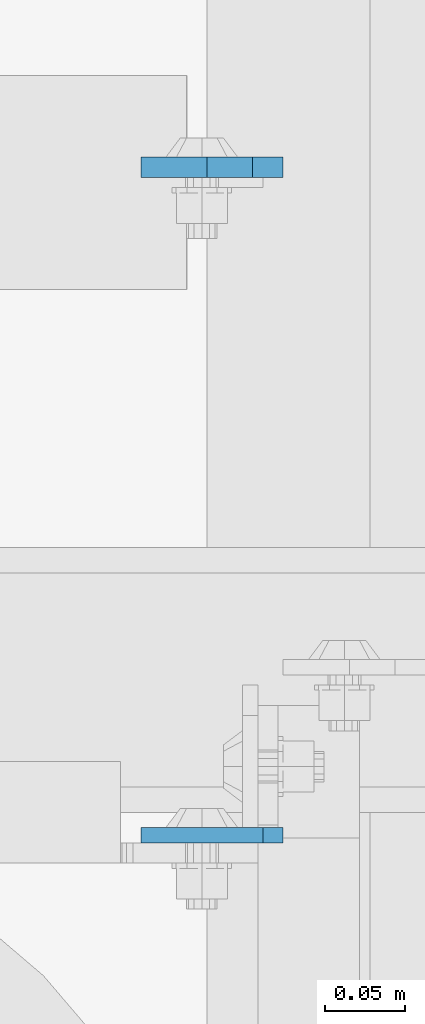
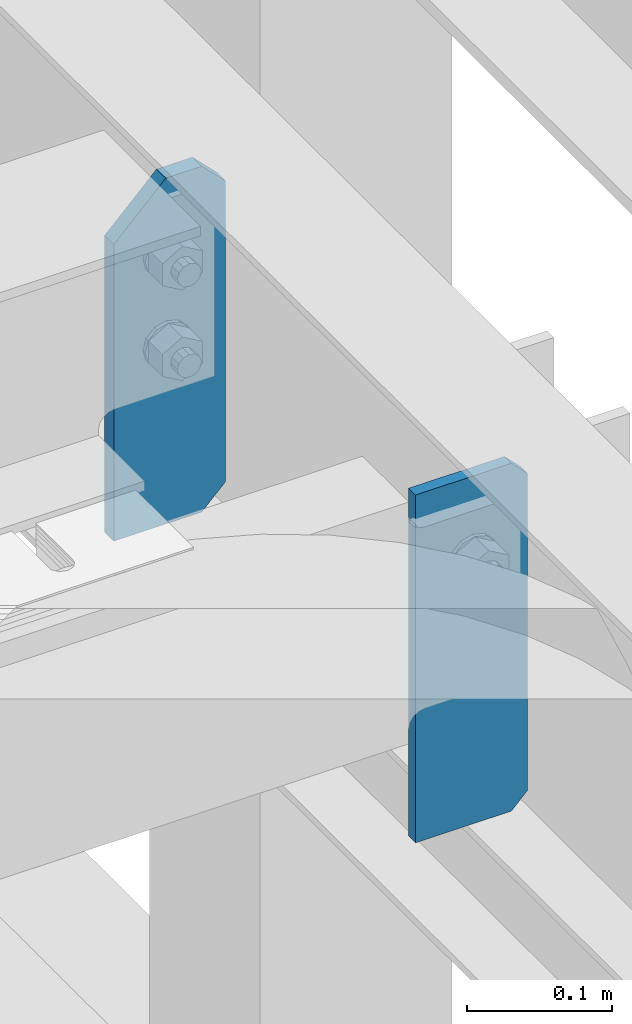
# One storey, part 1616 of 1876: 2 plates, 1 element without a shape of its own.
"""IFC2X3 building model written with IfcOpenShell, lengths in millimetres."""

from ifc_helpers import new_model, si_unit, frame, origin_with_axes, place, context, subcontext, project, spatial, faceted_brep, material, type_object, element, aggregate, save


model = new_model("IFC2X3")

# Units and contexts
model_context = context("Model", 3, precision=1e-05, world=origin_with_axes())
body_context = subcontext(model_context, "Body", "Model", "MODEL_VIEW")
ifc_project = project(units=[si_unit("LENGTHUNIT", "METRE", prefix="MILLI"), si_unit("AREAUNIT", "SQUARE_METRE"), si_unit("VOLUMEUNIT", "CUBIC_METRE"), si_unit("MASSUNIT", "GRAM", prefix="KILO"), si_unit("TIMEUNIT", "SECOND"), si_unit("PLANEANGLEUNIT", "RADIAN"), si_unit("SOLIDANGLEUNIT", "STERADIAN"), si_unit("THERMODYNAMICTEMPERATUREUNIT", "DEGREE_CELSIUS"), si_unit("LUMINOUSINTENSITYUNIT", "LUMEN")], contexts=[model_context])

# Site, building, storey
site_placement = place(None, origin_with_axes())
site = spatial("IfcSite", under=ifc_project, at=site_placement, CompositionType="ELEMENT")
building_placement = place(site_placement, origin_with_axes())
building = spatial("IfcBuilding", under=site, at=building_placement, Name="Undefined", CompositionType="ELEMENT")
storey_placement = place(building_placement, origin_with_axes())
storey = spatial("IfcBuildingStorey", under=building, at=storey_placement, Name="Undefined", CompositionType="ELEMENT", Elevation=0.0)

# Assembly, plates
assembly_placement = place(storey_placement, origin_with_axes())
assembly = element("IfcElementAssembly", 1, at=assembly_placement, inside=storey, Name="BEAM", AssemblyPlace="NOTDEFINED", PredefinedType="RIGID_FRAME")
ifc_material = material(Name="STEEL/A36")
plate_type_1 = type_object("IfcPlateType", PredefinedType="NOTDEFINED")
plate_1_placement = place(assembly_placement, frame((2854.325, 3122.61290163829, 17684.75), z_axis=(0.0, 0.0, 1.0), x_axis=(-1.0, 0.0, 0.0)))
plate_1 = element("IfcPlate", 2, at=plate_1_placement, type_object=plate_type_1, material=ifc_material, Name="PLATE", context=body_context, shape_type="Brep", body=[
    faceted_brep([(3.7040990719106e-08, -4.76249999999982, 12.6999998092651), (0.0, -4.76249999999982, 279.40000629425), (0.0, 4.76249999999982, 279.40000629425), (3.70396264770534e-08, 4.76249999999982, 12.6999998092651), (12.6999998092651, -4.76249999999982, 292.100006103516), (12.6999998092651, 4.76249999999982, 292.100006103516), (88.9000015258789, -4.76249999999982, 292.100006103516), (88.9000015258789, 4.76249999999982, 292.100006103516), (88.9000015258789, -4.76249999999982, 0.0), (88.9000015258789, 4.76249999999982, 0.0), (12.699999809267, -4.76249999999754, 1.09139364212751e-11), (12.6999998092651, 4.76250000000255, 1.09139364212751e-11)], [[[0, 1, 2, 3]], [[1, 4, 5, 2]], [[4, 6, 7, 5]], [[6, 8, 9, 7]], [[8, 10, 11, 9]], [[10, 0, 3, 11]], [[5, 7, 9, 11, 3, 2]], [[10, 8, 6, 4, 1, 0]]]),
])
plate_type_2 = type_object("IfcPlateType", PredefinedType="NOTDEFINED")
plate_2_placement = place(assembly_placement, frame((2854.325, 3539.32356576919, 17686.3375), z_axis=(0.0, 0.0, 1.0), x_axis=(-1.0, 0.0, 0.0)))
plate_2 = element("IfcPlate", 3, at=plate_2_placement, type_object=plate_type_2, material=ifc_material, Name="PLATE", context=body_context, shape_type="Brep", body=[
    faceted_brep([(0.0, -6.35000000000036, 271.462512969971), (19.0499992370605, -6.35000000000036, 290.512512207031), (19.0499992370605, 6.35000000000036, 290.512512207031), (0.0, 6.35000000000036, 271.462512969971), (0.0, -6.35000000000196, 19.0499992370605), (0.0, 6.35000000000105, 19.0499992370605), (19.0499992370642, -6.35000000000105, 0.0), (19.0499992370633, 6.35000000000105, 0.0), (88.9000015258789, -6.34999999999991, 0.0), (88.9000015258789, 6.34999999999991, 0.0), (88.9000015258789, -6.35000000000036, 249.237510681152), (47.625, -6.35000000000036, 290.512512207031), (47.625, 6.35000000000036, 290.512512207031), (88.9000015258789, 6.35000000000036, 249.237510681152)], [[[0, 1, 2, 3]], [[4, 0, 3, 5]], [[6, 4, 5, 7]], [[8, 6, 7, 9]], [[6, 8, 10, 11, 1, 0, 4]], [[1, 11, 12, 2]], [[2, 12, 13, 9, 7, 5, 3]], [[10, 8, 9, 13]], [[11, 10, 13, 12]]]),
])
aggregate(assembly, [plate_1, plate_2])

save(model, "model.ifc")
